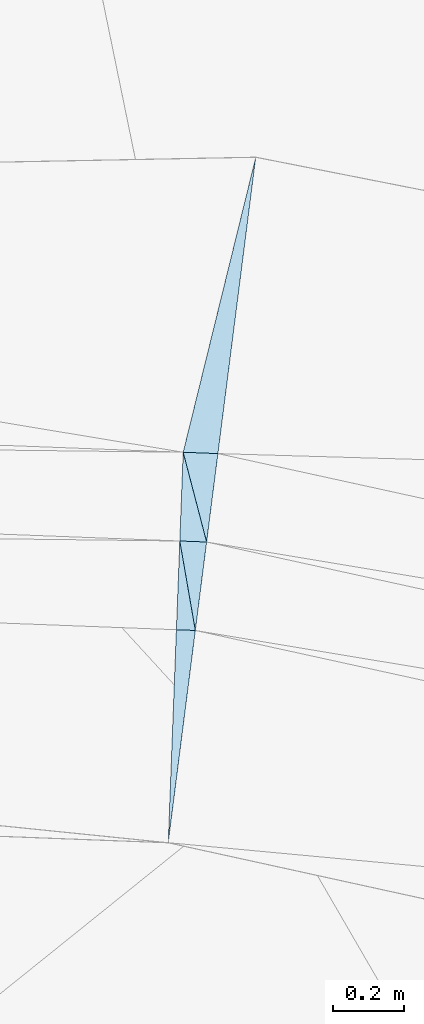
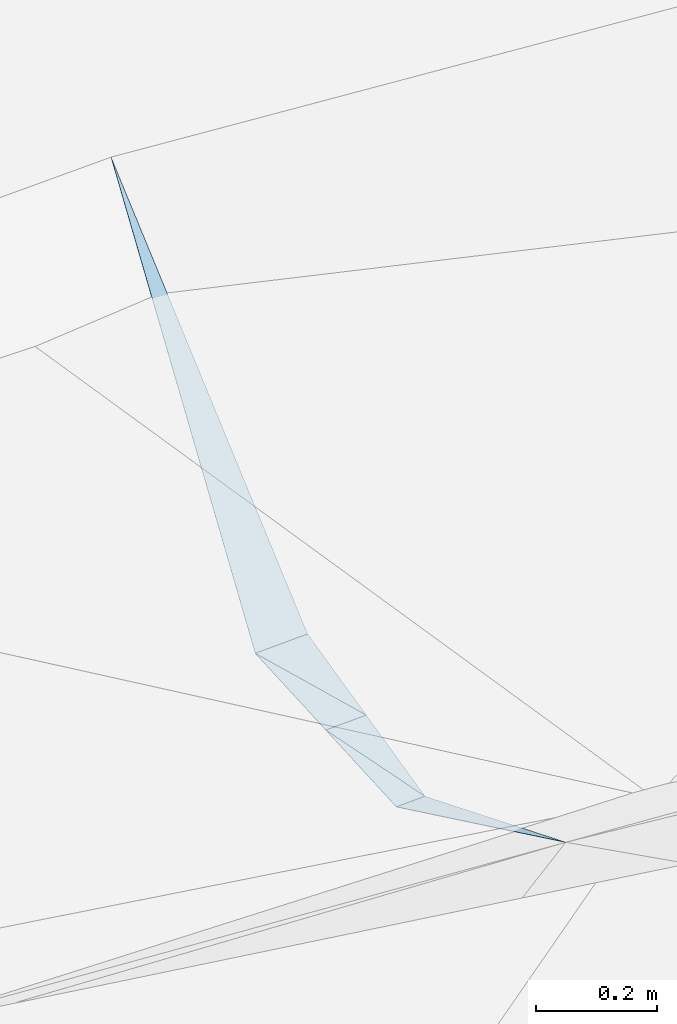
# One storey, part 184 of 275: 6 plates.
"""IFC2X3 building model written with IfcOpenShell, lengths in millimetres."""

from ifc_helpers import new_model, si_unit, frame, origin_with_axes, place, context, subcontext, project, spatial, polyline, outline, extrude, material, type_object, element, save


model = new_model("IFC2X3")

# Units and contexts
model_context = context("Model", 3, precision=1e-05, world=origin_with_axes())
body_context = subcontext(model_context, "Body", "Model", "MODEL_VIEW")
ifc_project = project(units=[si_unit("LENGTHUNIT", "METRE", prefix="MILLI"), si_unit("AREAUNIT", "SQUARE_METRE"), si_unit("VOLUMEUNIT", "CUBIC_METRE"), si_unit("MASSUNIT", "GRAM", prefix="KILO"), si_unit("TIMEUNIT", "SECOND"), si_unit("PLANEANGLEUNIT", "RADIAN"), si_unit("SOLIDANGLEUNIT", "STERADIAN"), si_unit("THERMODYNAMICTEMPERATUREUNIT", "DEGREE_CELSIUS"), si_unit("LUMINOUSINTENSITYUNIT", "LUMEN")], contexts=[model_context])

# Site, building, storey
site_placement = place(None, origin_with_axes())
site = spatial("IfcSite", under=ifc_project, at=site_placement, CompositionType="ELEMENT")
building_placement = place(site_placement, origin_with_axes())
building = spatial("IfcBuilding", under=site, at=building_placement, Name="Undefined", CompositionType="ELEMENT")
storey_placement = place(building_placement, origin_with_axes())
storey = spatial("IfcBuildingStorey", under=building, at=storey_placement, Name="Undefined", CompositionType="ELEMENT", Elevation=0.0)

# Plates
ifc_material = material()
plate_type_1 = type_object("IfcPlateType", PredefinedType="NOTDEFINED")
plate_1_placement = place(storey_placement, frame((-34157.2346908759, 72108.6168502307, 45286.9127208285), z_axis=(0.0474148397849166, -0.44842505213398, -0.892561933754072), x_axis=(0.0342467029960756, 0.893771397799774, -0.447213429817281)))
element("IfcPlate", 1, at=plate_1_placement, inside=storey, type_object=plate_type_1, material=ifc_material, Name="00_PR", context=body_context, shape_type="SweptSolid", body=[
    extrude(outline(polyline([(0.0, 0.0), (670.820617675781, -4.27826307713985e-09), (669.094909667969, 53.4896011352539), (0.0, 0.0)])), frame((-8.85201319254618e-08, 2.18876761149539e-07, -0.5000001331573), z_axis=(0.0, 0.0, 1.0), x_axis=(1.0, 0.0, 0.0)), (0.0, 0.0, 1.0), 1.0),
])
plate_type_2 = type_object("IfcPlateType", PredefinedType="NOTDEFINED")
plate_2_placement = place(storey_placement, frame((-34049.1133275293, 72955.3214202143, 44992.3142874415), z_axis=(0.0715966847009062, -0.00282976330197032, -0.997429650240805), x_axis=(-0.252610317910678, 0.967342842568595, -0.0208770739419501)))
element("IfcPlate", 2, at=plate_2_placement, inside=storey, type_object=plate_type_2, material=ifc_material, Name="00_PR", context=body_context, shape_type="SweptSolid", body=[
    extrude(outline(polyline([(0.0, 0.0), (261.243499755859, -7.6397554948926e-11), (232.769897460938, 93.8897857666016), (0.0, 0.0)])), frame((-8.85201319254618e-08, 2.18876761149539e-07, -0.5000001331573), z_axis=(0.0, 0.0, 1.0), x_axis=(1.0, 0.0, 0.0)), (0.0, 0.0, 1.0), 1.0),
])
plate_type_3 = type_object("IfcPlateType", PredefinedType="NOTDEFINED")
plate_3_placement = place(storey_placement, frame((-34124.6774304704, 72958.2167327312, 44986.860304916), z_axis=(0.0720731513247873, -0.00276142692668687, -0.997395526047437), x_axis=(0.17119125103493, -0.985122128080997, 0.015097957950096)))
element("IfcPlate", 3, at=plate_3_placement, inside=storey, type_object=plate_type_3, material=ifc_material, Name="00_PR", context=body_context, shape_type="SweptSolid", body=[
    extrude(outline(polyline([(0.0, 0.0), (255.663711547852, 1.67347025126219e-09), (244.461441040039, 52.3318710327148), (0.0, 0.0)])), frame((-8.85201319254618e-08, 2.18876761149539e-07, -0.5000001331573), z_axis=(0.0, 0.0, 1.0), x_axis=(1.0, 0.0, 0.0)), (0.0, 0.0, 1.0), 1.0),
])
plate_type_4 = type_object("IfcPlateType", PredefinedType="NOTDEFINED")
plate_4_placement = place(storey_placement, frame((-33910.7782906447, 74038.6586348397, 45412.7505757312), z_axis=(0.0811484715358956, 0.438922197717628, -0.894853189030533), x_axis=(-0.11340154996428, -0.887918161106047, -0.445804248122149)))
element("IfcPlate", 4, at=plate_4_placement, inside=storey, type_object=plate_type_4, material=ifc_material, Name="00_PR", context=body_context, shape_type="SweptSolid", body=[
    extrude(outline(polyline([(0.0, 0.0), (939.445983886719, 3.51428752765059e-09), (950.342468261719, 97.5054092407227), (0.0, 0.0)])), frame((-8.85201319254618e-08, 2.18876761149539e-07, -0.5000001331573), z_axis=(0.0, 0.0, 1.0), x_axis=(1.0, 0.0, 0.0)), (0.0, 0.0, 1.0), 1.0),
])
plate_type_5 = type_object("IfcPlateType", PredefinedType="NOTDEFINED")
plate_5_placement = place(storey_placement, frame((-34115.1059873233, 73208.0334909706, 44986.8602977548), z_axis=(0.0718843752873082, -0.00275419424350845, -0.997409169299953), x_axis=(0.252610317916424, -0.967342842566982, 0.020877073947157)))
element("IfcPlate", 5, at=plate_5_placement, inside=storey, type_object=plate_type_5, material=ifc_material, Name="00_PR", context=body_context, shape_type="SweptSolid", body=[
    extrude(outline(polyline([(0.0, 0.0), (261.243499755859, -7.6397554948926e-11), (239.240585327148, 72.55322265625), (0.0, 0.0)])), frame((-8.85201319254618e-08, 2.18876761149539e-07, -0.5000001331573), z_axis=(0.0, 0.0, 1.0), x_axis=(1.0, 0.0, 0.0)), (0.0, 0.0, 1.0), 1.0),
])
plate_type_6 = type_object("IfcPlateType", PredefinedType="NOTDEFINED")
plate_6_placement = place(storey_placement, frame((-34080.9101356163, 72706.3567444738, 44990.7202970181), z_axis=(0.0718828225224285, -0.00279471071091425, -0.997409168505208), x_axis=(-0.171191251033847, 0.985122128081289, -0.0150979579433125)))
element("IfcPlate", 6, at=plate_6_placement, inside=storey, type_object=plate_type_6, material=ifc_material, Name="00_PR", context=body_context, shape_type="SweptSolid", body=[
    extrude(outline(polyline([(0.0, 0.0), (255.663711547852, 1.67347025126219e-09), (239.793197631836, 74.1365356445313), (0.0, 0.0)])), frame((-8.85201319254618e-08, 2.18876761149539e-07, -0.5000001331573), z_axis=(0.0, 0.0, 1.0), x_axis=(1.0, 0.0, 0.0)), (0.0, 0.0, 1.0), 1.0),
])

save(model, "model.ifc")
